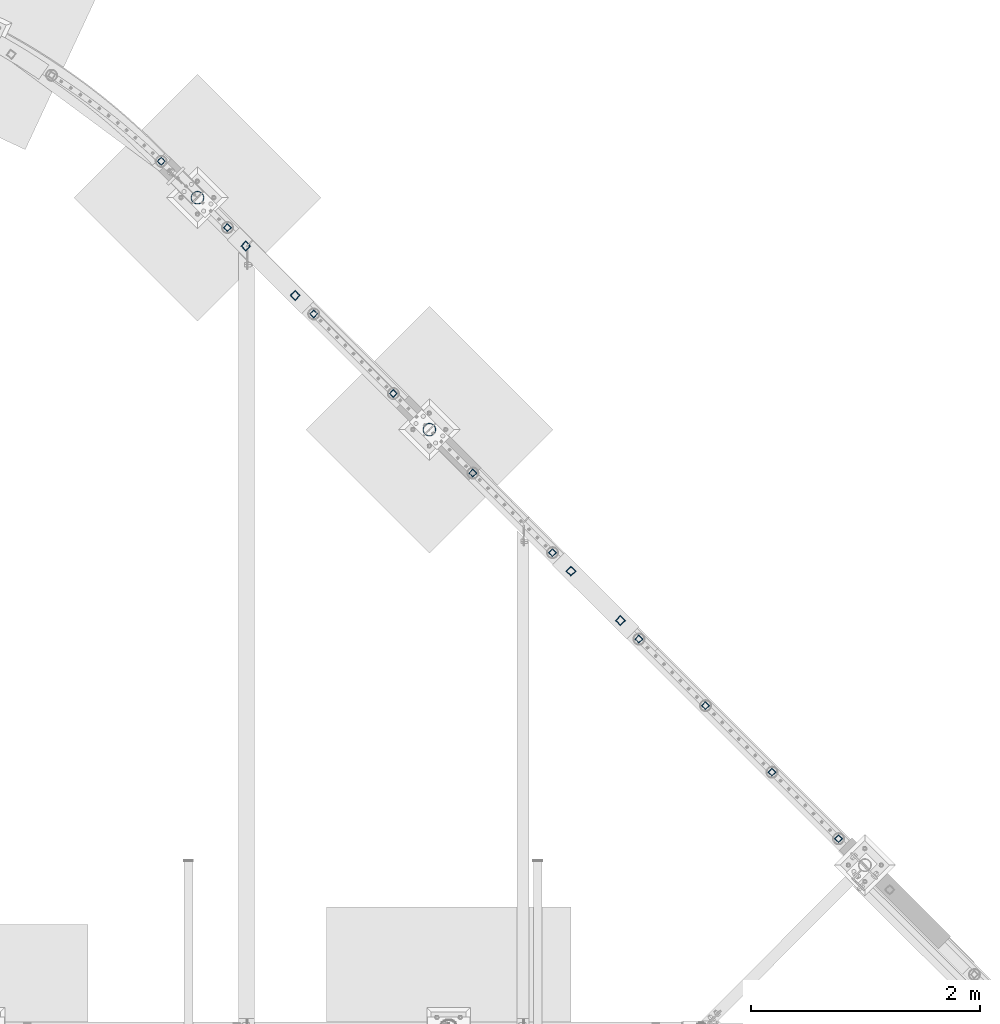
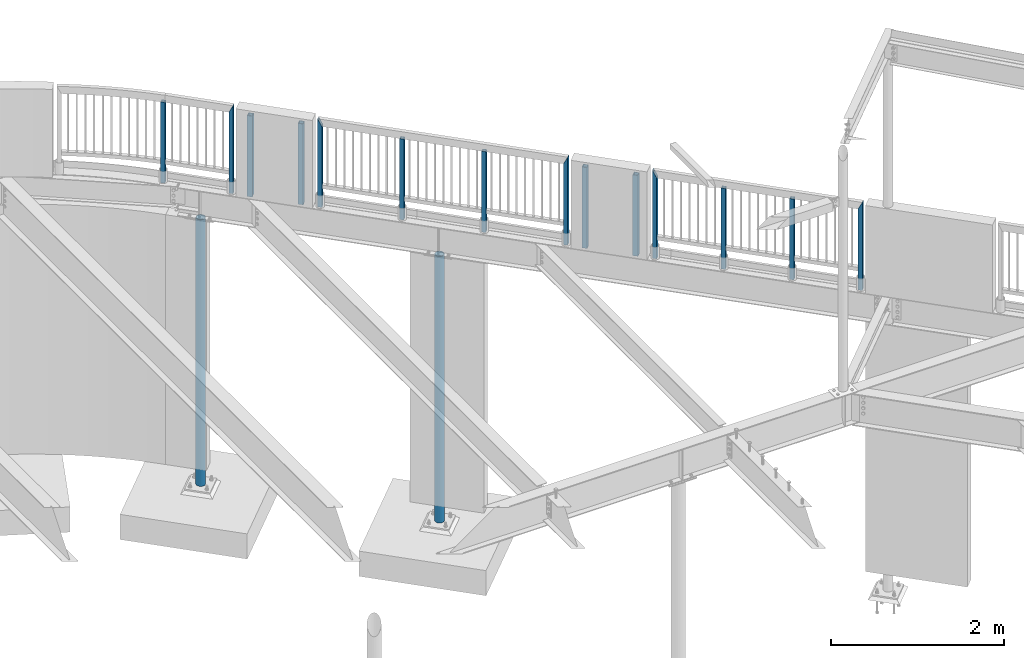
# One storey, part 131 of 975: 16 columns.
"""IFC2X3 building model written with IfcOpenShell, lengths in millimetres."""

from ifc_helpers import new_model, si_unit, frame, origin_with_axes, place, context, subcontext, project, spatial, faceted_brep, material, type_object, element, save


model = new_model("IFC2X3")

# Units and contexts
model_context = context("Model", 3, precision=1e-05, world=origin_with_axes())
body_context = subcontext(model_context, "Body", "Model", "MODEL_VIEW")
ifc_project = project(units=[si_unit("LENGTHUNIT", "METRE", prefix="MILLI"), si_unit("AREAUNIT", "SQUARE_METRE"), si_unit("VOLUMEUNIT", "CUBIC_METRE"), si_unit("MASSUNIT", "GRAM", prefix="KILO"), si_unit("TIMEUNIT", "SECOND"), si_unit("PLANEANGLEUNIT", "RADIAN"), si_unit("SOLIDANGLEUNIT", "STERADIAN"), si_unit("THERMODYNAMICTEMPERATUREUNIT", "DEGREE_CELSIUS"), si_unit("LUMINOUSINTENSITYUNIT", "LUMEN")], contexts=[model_context])

# Site, building, storey
site_placement = place(None, origin_with_axes())
site = spatial("IfcSite", under=ifc_project, at=site_placement, CompositionType="ELEMENT")
building_placement = place(site_placement, origin_with_axes())
building = spatial("IfcBuilding", under=site, at=building_placement, Name="Undefined", CompositionType="ELEMENT")
storey_placement = place(building_placement, origin_with_axes())
storey = spatial("IfcBuildingStorey", under=building, at=storey_placement, Name="Undefined", CompositionType="ELEMENT", Elevation=0.0)

# Columns
ifc_material_1 = material()
column_type_1 = type_object("IfcColumnType", Name="HSS2X2X.188_TUBES", PredefinedType="NOTDEFINED")
column_1_placement = place(storey_placement, frame((20414.5989551812, 28221.5825873175, 3937.00002018607), z_axis=(-0.707106781186601, 0.707106781186494, 2.36468622460961e-14), x_axis=(0.0, 0.0, 1.0)))
element("IfcColumn", 1, at=column_1_placement, inside=storey, type_object=column_type_1, material=ifc_material_1, Name="HANDRAIL", ObjectType="HSS2X2X.188_TUBES", context=body_context, shape_type="Brep", body=[
    faceted_brep([(0.0, 20.6374999999753, -20.6375000000298), (0.0, -20.6375000000153, -20.6375000000153), (1142.99998821453, -20.6374999999462, -20.6374999999534), (1142.99998821453, 20.6374999999462, -20.6374999999516), (0.0, -20.6374999999825, 20.6375000000335), (1142.9999881907, -20.6375000000262, 20.6375000000335), (0.0, 20.6375000000116, 20.6375000000189), (1142.99998829488, 20.6375000000335, 20.637500000048), (0.0, 25.3999999999724, -25.4000000000342), (0.0, 25.400000000016, 25.4000000000196), (1143.0, 25.4000000000051, 25.4000000000378), (1143.0, 25.4000000000433, -25.4000000000087), (0.0, -25.399999999976, 25.4000000000378), (1143.0, -25.4000000000451, 25.4000000000087), (0.0, -25.400000000016, -25.4000000000196), (1143.0, -25.4000000000106, -25.4000000000451)], [[[0, 1, 2, 3]], [[1, 4, 5, 2]], [[4, 6, 7, 5]], [[6, 0, 3, 7]], [[8, 9, 10, 11]], [[9, 12, 13, 10]], [[12, 14, 15, 13]], [[14, 8, 11, 15]], [[13, 15, 11, 10], [5, 7, 3, 2]], [[14, 12, 9, 8], [6, 4, 1, 0]]]),
])
column_2_placement = place(storey_placement, frame((20992.0520801812, 27642.3435253175, 3937.00002018607), z_axis=(-0.707106781186601, 0.707106781186494, 2.36468622460961e-14), x_axis=(0.0, 0.0, 1.0)))
element("IfcColumn", 2, at=column_2_placement, inside=storey, type_object=column_type_1, material=ifc_material_1, Name="HANDRAIL", ObjectType="HSS2X2X.188_TUBES", context=body_context, shape_type="Brep", body=[
    faceted_brep([(0.0, 20.6374999999753, -20.6375000000298), (0.0, -20.6375000000153, -20.6375000000153), (1235.074979717, -20.6374999999462, -20.6374999999462), (1234.95979254369, 20.6374999999534, -20.6374999999462), (0.0, -20.6374999999825, 20.6375000000335), (1152.64016697719, -20.6374999999462, 20.6374999999516), (0.0, 20.6375000000116, 20.6375000000189), (1152.52497980387, 20.6374999999534, 20.6374999999534), (0.0, 25.3999999999724, -25.4000000000342), (0.0, 25.400000000016, 25.4000000000196), (1143.0, 25.4000000000051, 25.4000000000378), (1244.45821087828, 25.3999999999432, -25.3999999999342), (0.0, -25.399999999976, 25.4000000000378), (1143.14174864259, -25.399999999936, 25.3999999999414), (0.0, -25.400000000016, -25.4000000000196), (1244.59997970698, -25.399999999936, -25.399999999936)], [[[0, 1, 2, 3]], [[1, 4, 5, 2]], [[4, 6, 7, 5]], [[6, 0, 3, 7]], [[8, 9, 10, 11]], [[9, 12, 13, 10]], [[12, 14, 15, 13]], [[14, 8, 11, 15]], [[13, 15, 11, 10], [5, 7, 3, 2]], [[14, 12, 9, 8], [6, 4, 1, 0]]]),
])
for number, where, z_axis, x_axis, name in (
    (3, (25744.4987497212, 22890.0361789292, 3937.0), (-0.707106781186601, 0.707106781186494, 2.36468622460961e-14), (-5.04999999806568e-07, 5.04999999806568e-07, 0.999999999999745), "HANDRAIL"),
    (4, (23134.193376057, 25500.2478312396, 3937.00001429355), (-0.707106781186601, 0.707106781186494, 2.36468622460961e-14), (-5.04999999806568e-07, 5.04999999806568e-07, 0.999999999999745), "HANDRAIL"),
):
    element("IfcColumn", number, at=place(storey_placement, frame(where, z_axis=z_axis, x_axis=x_axis)), inside=storey, type_object=column_type_1, material=ifc_material_1, Name=name, ObjectType="HSS2X2X.188_TUBES", context=body_context, shape_type="Brep", body=[
        faceted_brep([(0.0, 20.6374999999753, -20.6375000000298), (0.0, -20.6375000000153, -20.6375000000153), (1142.99998821453, -20.6374999999462, -20.6374999999534), (1142.99998821453, 20.6374999999462, -20.6374999999516), (0.0, -20.6374999999825, 20.6375000000335), (1142.9999881907, -20.6375000000262, 20.6375000000335), (0.0, 20.6375000000116, 20.6375000000189), (1142.99998829488, 20.6375000000335, 20.637500000048), (0.0, 25.3999999999724, -25.4000000000342), (0.0, 25.400000000016, 25.4000000000196), (1143.0, 25.4000000000051, 25.4000000000378), (1143.0, 25.4000000000433, -25.4000000000087), (0.0, -25.399999999976, 25.4000000000378), (1143.0, -25.4000000000451, 25.4000000000087), (0.0, -25.400000000016, -25.4000000000196), (1143.0, -25.4000000000106, -25.4000000000451)], [[[0, 1, 2, 3]], [[1, 4, 5, 2]], [[4, 6, 7, 5]], [[6, 0, 3, 7]], [[8, 9, 10, 11]], [[9, 12, 13, 10]], [[12, 14, 15, 13]], [[14, 8, 11, 15]], [[13, 15, 11, 10], [5, 7, 3, 2]], [[14, 12, 9, 8], [6, 4, 1, 0]]]),
    ])
column_3_placement = place(storey_placement, frame((21745.3208301812, 26889.2732113175, 3937.00002018607), z_axis=(-0.707106781186601, 0.707106781186494, 2.36468622460961e-14), x_axis=(0.0, 0.0, 1.0)))
element("IfcColumn", 5, at=column_3_placement, inside=storey, type_object=column_type_1, material=ifc_material_1, Name="HANDRAIL", ObjectType="HSS2X2X.188_TUBES", context=body_context, shape_type="Brep", body=[
    faceted_brep([(0.0, 20.6374999999753, -20.6375000000298), (0.0, -20.6375000000153, -20.6375000000153), (1152.52497983932, -20.6374999999462, -20.6374999999525), (1152.5298588527, 20.6374999999998, -20.6375000005173), (0.0, -20.6374999999825, 20.6375000000335), (1235.07010081906, -20.6374999999998, 20.6374999994514), (0.0, 20.6375000000116, 20.6375000000189), (1235.07497982248, 20.6374999999534, 20.6374999999471), (0.0, 25.3999999999724, -25.4000000000342), (0.0, 25.400000000016, 25.4000000000196), (1244.59997982054, 25.399999999936, 25.3999999999351), (1143.00598477966, 25.4000000000001, -25.4000000005108), (0.0, -25.399999999976, 25.4000000000378), (1244.59397489211, -25.4000000000001, 25.3999999994448), (0.0, -25.400000000016, -25.4000000000196), (1143.0, -25.4000000000106, -25.4000000000451)], [[[0, 1, 2, 3]], [[1, 4, 5, 2]], [[4, 6, 7, 5]], [[6, 0, 3, 7]], [[8, 9, 10, 11]], [[9, 12, 13, 10]], [[12, 14, 15, 13]], [[14, 8, 11, 15]], [[13, 15, 11, 10], [5, 7, 3, 2]], [[14, 12, 9, 8], [6, 4, 1, 0]]]),
])
column_4_placement = place(storey_placement, frame((22439.8001211003, 26194.8029317337, 3937.00001429355), z_axis=(-0.707106781186601, 0.707106781186494, 2.36468622460961e-14), x_axis=(-5.04999999806568e-07, 5.04999999806568e-07, 0.999999999999745)))
element("IfcColumn", 6, at=column_4_placement, inside=storey, type_object=column_type_1, material=ifc_material_1, Name="HANDRAIL", ObjectType="HSS2X2X.188_TUBES", context=body_context, shape_type="Brep", body=[
    faceted_brep([(0.0, 20.6374999999753, -20.6375000000298), (0.0, -20.6375000000153, -20.6375000000153), (1142.99998821453, -20.6374999999462, -20.6374999999534), (1142.99998821453, 20.6374999999462, -20.6374999999516), (0.0, -20.6374999999825, 20.6375000000335), (1142.9999881907, -20.6375000000262, 20.6375000000335), (0.0, 20.6375000000116, 20.6375000000189), (1142.99998829488, 20.6375000000335, 20.637500000048), (0.0, 25.3999999999724, -25.4000000000342), (0.0, 25.400000000016, 25.4000000000196), (1143.0, 25.4000000000051, 25.4000000000378), (1143.0, 25.4000000000433, -25.4000000000087), (0.0, -25.399999999976, 25.4000000000378), (1143.0, -25.4000000000451, 25.4000000000087), (0.0, -25.400000000016, -25.4000000000196), (1143.0, -25.4000000000106, -25.4000000000451)], [[[0, 1, 2, 3]], [[1, 4, 5, 2]], [[4, 6, 7, 5]], [[6, 0, 3, 7]], [[8, 9, 10, 11]], [[9, 12, 13, 10]], [[12, 14, 15, 13]], [[14, 8, 11, 15]], [[13, 15, 11, 10], [5, 7, 3, 2]], [[14, 12, 9, 8], [6, 4, 1, 0]]]),
])
column_5_placement = place(storey_placement, frame((23828.6202251717, 24805.7275258393, 3937.00001178547), z_axis=(-0.707106781186601, 0.707106781186494, 2.36468622460961e-14), x_axis=(0.0, 0.0, 1.0)))
element("IfcColumn", 7, at=column_5_placement, inside=storey, type_object=column_type_1, material=ifc_material_1, Name="HANDRAIL", ObjectType="HSS2X2X.188_TUBES", context=body_context, shape_type="Brep", body=[
    faceted_brep([(0.0, 20.6374999999753, -20.6375000000298), (0.0, -20.6375000000153, -20.6375000000153), (1235.074979717, -20.6374999999462, -20.6374999999462), (1235.07010917575, 20.6374999999871, -20.6375000000007), (0.0, -20.6374999999825, 20.6375000000335), (1152.5298672094, -20.6375000000121, 20.6375000000007), (0.0, 20.6375000000116, 20.6375000000189), (1152.52497980387, 20.6374999999534, 20.6374999999534), (0.0, 25.3999999999724, -25.4000000000342), (0.0, 25.400000000016, 25.4000000000196), (1143.0, 25.4000000000051, 25.4000000000378), (1244.5939832488, 25.3999999999869, -25.4000000000015), (0.0, -25.399999999976, 25.4000000000378), (1143.00599313636, -25.4000000000124, 25.4000000000015), (0.0, -25.400000000016, -25.4000000000196), (1244.59997970698, -25.399999999936, -25.399999999936)], [[[0, 1, 2, 3]], [[1, 4, 5, 2]], [[4, 6, 7, 5]], [[6, 0, 3, 7]], [[8, 9, 10, 11]], [[9, 12, 13, 10]], [[12, 14, 15, 13]], [[14, 8, 11, 15]], [[13, 15, 11, 10], [5, 7, 3, 2]], [[14, 12, 9, 8], [6, 4, 1, 0]]]),
])
column_6_placement = place(storey_placement, frame((24583.0999040427, 24051.5357113111, 3937.00002018607), z_axis=(-0.707106781186601, 0.707106781186494, 2.36468622460961e-14), x_axis=(0.0, 0.0, 1.0)))
element("IfcColumn", 8, at=column_6_placement, inside=storey, type_object=column_type_1, material=ifc_material_1, Name="HANDRAIL", ObjectType="HSS2X2X.188_TUBES", context=body_context, shape_type="Brep", body=[
    faceted_brep([(0.0, 20.6374999999753, -20.6375000000298), (0.0, -20.6375000000153, -20.6375000000153), (1152.52497983932, -20.6374999999462, -20.6374999999525), (1152.52900291014, 20.6374999999462, -20.6374999999489), (0.0, -20.6374999999825, 20.6375000000335), (1235.07095675167, -20.6374999999462, 20.6374999999471), (0.0, 20.6375000000116, 20.6375000000189), (1235.07497982248, 20.6374999999534, 20.6374999999471), (0.0, 25.3999999999724, -25.4000000000342), (0.0, 25.400000000016, 25.4000000000196), (1244.59997982054, 25.399999999936, 25.3999999999351), (1143.00493131304, 25.399999999936, -25.3999999999387), (0.0, -25.399999999976, 25.4000000000378), (1244.59502834876, -25.399999999936, 25.3999999999369), (0.0, -25.400000000016, -25.4000000000196), (1143.0, -25.4000000000106, -25.4000000000451)], [[[0, 1, 2, 3]], [[1, 4, 5, 2]], [[4, 6, 7, 5]], [[6, 0, 3, 7]], [[8, 9, 10, 11]], [[9, 12, 13, 10]], [[12, 14, 15, 13]], [[14, 8, 11, 15]], [[13, 15, 11, 10], [5, 7, 3, 2]], [[14, 12, 9, 8], [6, 4, 1, 0]]]),
])
column_7_placement = place(storey_placement, frame((25163.8423448718, 23470.8283555666, 3937.00001429334), z_axis=(-0.707106781186601, 0.707106781186494, 2.36468622460961e-14), x_axis=(-5.04999999806568e-07, 5.04999999806568e-07, 0.999999999999745)))
element("IfcColumn", 9, at=column_7_placement, inside=storey, type_object=column_type_1, material=ifc_material_1, Name="HANDRAIL", ObjectType="HSS2X2X.188_TUBES", context=body_context, shape_type="Brep", body=[
    faceted_brep([(0.0, 20.6374999999753, -20.6375000000298), (0.0, -20.6375000000153, -20.6375000000153), (1142.99998821453, -20.6374999999462, -20.6374999999534), (1142.99998821453, 20.6374999999462, -20.6374999999516), (0.0, -20.6374999999825, 20.6375000000335), (1142.9999881907, -20.6375000000262, 20.6375000000335), (0.0, 20.6375000000116, 20.6375000000189), (1142.99998829488, 20.6375000000335, 20.637500000048), (0.0, 25.3999999999724, -25.4000000000342), (0.0, 25.400000000016, 25.4000000000196), (1143.0, 25.4000000000051, 25.4000000000378), (1143.0, 25.4000000000433, -25.4000000000087), (0.0, -25.399999999976, 25.4000000000378), (1143.0, -25.4000000000451, 25.4000000000087), (0.0, -25.400000000016, -25.4000000000196), (1143.0, -25.4000000000106, -25.4000000000451)], [[[0, 1, 2, 3]], [[1, 4, 5, 2]], [[4, 6, 7, 5]], [[6, 0, 3, 7]], [[8, 9, 10, 11]], [[9, 12, 13, 10]], [[12, 14, 15, 13]], [[14, 8, 11, 15]], [[13, 15, 11, 10], [5, 7, 3, 2]], [[14, 12, 9, 8], [6, 4, 1, 0]]]),
])
column_8_placement = place(storey_placement, frame((26325.1887487134, 22309.2787974008, 3937.00001178547), z_axis=(-0.707106781186601, 0.707106781186494, 2.36468622460961e-14), x_axis=(0.0, 0.0, 1.0)))
element("IfcColumn", 10, at=column_8_placement, inside=storey, type_object=column_type_1, material=ifc_material_1, Name="HANDRAIL", ObjectType="HSS2X2X.188_TUBES", context=body_context, shape_type="Brep", body=[
    faceted_brep([(0.0, 20.6374999999753, -20.6375000000298), (0.0, -20.6375000000153, -20.6375000000153), (1235.074979717, -20.6374999999462, -20.6374999999462), (1235.07091767483, 20.6374999999871, -20.6375000000007), (0.0, -20.6374999999825, 20.6375000000335), (1152.52905859553, -20.6375000000121, 20.6375000000007), (0.0, 20.6375000000116, 20.6375000000189), (1152.52497980387, 20.6374999999534, 20.6374999999534), (0.0, 25.3999999999724, -25.4000000000342), (0.0, 25.400000000016, 25.4000000000196), (1143.0, 25.4000000000051, 25.4000000000378), (1244.59503672188, 25.399999999936, -25.3999999999396), (0.0, -25.399999999976, 25.4000000000378), (1143.00493968616, -25.399999999936, 25.399999999936), (0.0, -25.400000000016, -25.4000000000196), (1244.59997970698, -25.399999999936, -25.399999999936)], [[[0, 1, 2, 3]], [[1, 4, 5, 2]], [[4, 6, 7, 5]], [[6, 0, 3, 7]], [[8, 9, 10, 11]], [[9, 12, 13, 10]], [[12, 14, 15, 13]], [[14, 8, 11, 15]], [[13, 15, 11, 10], [5, 7, 3, 2]], [[14, 12, 9, 8], [6, 4, 1, 0]]]),
])
column_type_2 = type_object("IfcColumnType", Name="HSS2-1/2X2-1/2X1/4", PredefinedType="NOTDEFINED")
for number, where, z_axis, x_axis in (
    (11, (24421.4420888213, 24213.1973175499, 3937.0), (0.707115470133164, 0.70709809213316, 0.0), (0.0, 0.0, 1.0)),
    (12, (23990.395091857, 24644.2549081431, 3937.0), (0.707115470133164, 0.70709809213316, 0.0), (0.0, 0.0, 1.0)),
    (13, (21583.7233873893, 27050.9266126107, 3937.0), (0.707115470133164, 0.70709809213316, 0.0), (0.0, 0.0, 1.0)),
    (14, (21152.6313806827, 27482.0186193173, 3937.0), (0.707115470133164, 0.70709809213316, 0.0), (0.0, 0.0, 1.0)),
):
    element("IfcColumn", number, at=place(storey_placement, frame(where, z_axis=z_axis, x_axis=x_axis)), inside=storey, type_object=column_type_2, material=ifc_material_1, ObjectType="HSS2-1/2X2-1/2X1/4", context=body_context, shape_type="Brep", body=[
        faceted_brep([(0.0, 25.3999999999724, -25.4000000000342), (0.0, -25.400000000016, -25.4000000000196), (1143.0, -25.4000000000106, -25.4000000000451), (1143.0, 25.4000000000433, -25.4000000000087), (0.0, -25.399999999976, 25.4000000000378), (1143.0, -25.4000000000451, 25.4000000000087), (0.0, 25.400000000016, 25.4000000000196), (1143.0, 25.4000000000051, 25.4000000000378), (-5.45696821063757e-11, 31.7499999999909, -31.75000000002), (0.0, 31.7500000000127, 31.7500000000582), (1143.0, 31.7500000000127, 31.7500000000582), (1143.0, 31.7500000000546, -31.7500000000146), (0.0, -31.7500000000564, 31.7500000000073), (1143.0, -31.7500000000564, 31.7500000000073), (0.0, -31.7500000000146, -31.7500000000582), (1143.0, -31.7500000000146, -31.7500000000582)], [[[0, 1, 2, 3]], [[1, 4, 5, 2]], [[4, 6, 7, 5]], [[6, 0, 3, 7]], [[8, 9, 10, 11]], [[9, 12, 13, 10]], [[12, 14, 15, 13]], [[14, 8, 11, 15]], [[13, 15, 11, 10], [5, 7, 3, 2]], [[14, 12, 9, 8], [6, 4, 1, 0]]]),
    ])
ifc_material_2 = material(Name="STEEL/A53")
column_type_3 = type_object("IfcColumnType", Name="PIPE4STD", PredefinedType="NOTDEFINED")
column_9_placement = place(storey_placement, frame((20731.1625, 27903.4875, -266.7), z_axis=(-0.707106781186601, 0.707106781186494, 2.36468622460961e-14), x_axis=(0.0, 0.0, 1.0)))
element("IfcColumn", 15, at=column_9_placement, inside=storey, type_object=column_type_3, material=ifc_material_2, Name="COLUMN", ObjectType="PIPE4STD", context=body_context, shape_type="Brep", body=[
    faceted_brep([(19.0500000000025, -51.1301999999996, 0.0), (19.0500000000025, -48.6277098894743, 15.8001007257917), (3787.775, -48.6277098893624, 15.8001007257553), (3787.775, -51.1301999998759, 3.63797880709171e-12), (19.0500000000025, -41.3652007257897, 30.0535775067656), (3787.775, -41.3652007256969, 30.0535775066928), (19.0500000000025, -30.0535775067647, 41.3652007257915), (3787.775, -30.0535775066892, 41.3652007256933), (19.0500000000025, -15.8001007257899, 48.6277098894752), (3787.775, -15.8001007257553, 48.6277098893624), (19.0500000000025, 0.0, 51.1301999999996), (3787.775, -7.27595761418343e-12, 51.1301999998796), (19.0500000000025, 15.8001007257899, 48.6277098894752), (3787.775, 15.8001007257481, 48.6277098893606), (19.0500000000025, 30.0535775067647, 41.3652007257915), (3787.775, 30.0535775066892, 41.3652007256915), (19.0500000000025, 41.3652007257897, 30.0535775067656), (3787.775, 41.3652007256824, 30.0535775066928), (19.0500000000025, 48.6277098894743, 15.8001007257917), (3787.775, 48.6277098893552, 15.8001007257553), (19.0500000000025, 51.1301999999996, 0.0), (3787.775, 51.1301999998759, 1.81898940354586e-12), (19.0500000000025, 48.6277098894743, -15.8001007257917), (3787.775, 48.6277098893552, -15.8001007257481), (19.0500000000025, 41.3652007257897, -30.0535775067656), (3787.775, 41.3652007256896, -30.0535775066874), (19.0500000000025, 30.0535775067647, -41.3652007257915), (3787.775, 30.0535775066892, -41.3652007256878), (19.0500000000025, 15.8001007257899, -48.6277098894752), (3787.775, 15.8001007257481, -48.6277098893552), (19.0500000000025, 0.0, -51.1301999999996), (3787.775, 0.0, -51.1301999998741), (19.0500000000025, -15.8001007257899, -48.6277098894752), (3787.775, -15.8001007257553, -48.6277098893552), (19.0500000000025, -30.0535775067647, -41.3652007257915), (3787.775, -30.0535775066892, -41.365200725686), (19.0500000000025, -41.3652007257897, -30.0535775067656), (3787.775, -41.3652007256896, -30.0535775066874), (19.0500000000025, -48.6277098894743, -15.8001007257917), (3787.775, -48.6277098893624, -15.8001007257499), (19.0500000000025, -57.1499999999996, 0.0), (19.0500000000025, -54.3528799062678, -17.6603212285299), (3787.775, -54.3528799061387, -17.6603212284826), (3787.775, -57.1499999998705, 3.63797880709171e-12), (19.0500000000025, -46.2353212285279, -33.5919271685161), (3787.775, -46.2353212284215, -33.5919271684324), (19.0500000000025, -33.5919271685152, -46.235321228527), (3787.775, -33.5919271684397, -46.2353212284161), (19.0500000000025, -17.6603212285281, -54.3528799062697), (3787.775, -17.6603212284899, -54.3528799061332), (19.0500000000025, 0.0, -57.1500000000015), (3787.775, 0.0, -57.1499999998614), (19.0500000000025, 17.6603212285281, -54.3528799062697), (3787.775, 17.6603212284826, -54.3528799061314), (19.0500000000025, 33.5919271685152, -46.235321228527), (3787.775, 33.5919271684324, -46.2353212284143), (19.0500000000025, 46.2353212285279, -33.5919271685161), (3787.775, 46.2353212284143, -33.5919271684324), (19.0500000000025, 54.3528799062678, -17.6603212285299), (3787.775, 54.3528799061314, -17.6603212284826), (19.0500000000025, 57.1499999999996, 0.0), (3787.775, 57.1499999998632, 1.81898940354586e-12), (19.0500000000025, 54.3528799062678, 17.6603212285299), (3787.775, 54.3528799061314, 17.6603212284881), (19.0500000000025, 46.2353212285279, 33.5919271685161), (3787.775, 46.2353212284143, 33.5919271684379), (19.0500000000025, 33.5919271685152, 46.235321228527), (3787.775, 33.5919271684324, 46.2353212284215), (19.0500000000025, 17.6603212285281, 54.3528799062697), (3787.775, 17.6603212284826, 54.3528799061387), (19.0500000000025, 0.0, 57.1500000000015), (3787.775, -7.27595761418343e-12, 57.1499999998668), (19.0500000000025, -17.6603212285281, 54.3528799062697), (3787.775, -17.6603212284899, 54.3528799061369), (19.0500000000025, -33.5919271685152, 46.235321228527), (3787.775, -33.5919271684397, 46.2353212284197), (19.0500000000025, -46.2353212285279, 33.5919271685161), (3787.775, -46.2353212284215, 33.5919271684379), (19.0500000000025, -54.3528799062678, 17.6603212285299), (3787.775, -54.3528799061387, 17.6603212284881)], [[[0, 1, 2, 3]], [[1, 4, 5, 2]], [[4, 6, 7, 5]], [[6, 8, 9, 7]], [[8, 10, 11, 9]], [[10, 12, 13, 11]], [[12, 14, 15, 13]], [[14, 16, 17, 15]], [[16, 18, 19, 17]], [[18, 20, 21, 19]], [[20, 22, 23, 21]], [[22, 24, 25, 23]], [[24, 26, 27, 25]], [[26, 28, 29, 27]], [[28, 30, 31, 29]], [[30, 32, 33, 31]], [[32, 34, 35, 33]], [[34, 36, 37, 35]], [[36, 38, 39, 37]], [[38, 0, 3, 39]], [[40, 41, 42, 43]], [[41, 44, 45, 42]], [[44, 46, 47, 45]], [[46, 48, 49, 47]], [[48, 50, 51, 49]], [[50, 52, 53, 51]], [[52, 54, 55, 53]], [[54, 56, 57, 55]], [[56, 58, 59, 57]], [[58, 60, 61, 59]], [[60, 62, 63, 61]], [[62, 64, 65, 63]], [[64, 66, 67, 65]], [[66, 68, 69, 67]], [[68, 70, 71, 69]], [[70, 72, 73, 71]], [[72, 74, 75, 73]], [[74, 76, 77, 75]], [[76, 78, 79, 77]], [[78, 40, 43, 79]], [[45, 47, 49, 51, 53, 55, 57, 59, 61, 63, 65, 67, 69, 71, 73, 75, 77, 79, 43, 42], [5, 7, 9, 11, 13, 15, 17, 19, 21, 23, 25, 27, 29, 31, 33, 35, 37, 39, 3, 2]], [[78, 76, 74, 72, 70, 68, 66, 64, 62, 60, 58, 56, 54, 52, 50, 48, 46, 44, 41, 40], [38, 36, 34, 32, 30, 28, 26, 24, 22, 20, 18, 16, 14, 12, 10, 8, 6, 4, 1, 0]]]),
])
column_10_placement = place(storey_placement, frame((22755.225, 25879.425, -266.7), z_axis=(-0.707106781186601, 0.707106781186494, 2.36468622460961e-14), x_axis=(0.0, 0.0, 1.0)))
element("IfcColumn", 16, at=column_10_placement, inside=storey, type_object=column_type_3, material=ifc_material_2, Name="COLUMN", ObjectType="PIPE4STD", context=body_context, shape_type="Brep", body=[
    faceted_brep([(19.0500000000025, -51.1301999999996, 0.0), (19.0500000000025, -48.6277098894743, 15.8001007257917), (3787.775, -48.6277098893624, 15.8001007257553), (3787.775, -51.1301999998759, 3.63797880709171e-12), (19.0500000000025, -41.3652007257897, 30.0535775067656), (3787.775, -41.3652007256969, 30.0535775066928), (19.0500000000025, -30.0535775067647, 41.3652007257915), (3787.775, -30.0535775066892, 41.3652007256933), (19.0500000000025, -15.8001007257899, 48.6277098894752), (3787.775, -15.8001007257553, 48.6277098893624), (19.0500000000025, 0.0, 51.1301999999996), (3787.775, -7.27595761418343e-12, 51.1301999998796), (19.0500000000025, 15.8001007257899, 48.6277098894752), (3787.775, 15.8001007257481, 48.6277098893606), (19.0500000000025, 30.0535775067647, 41.3652007257915), (3787.775, 30.0535775066892, 41.3652007256915), (19.0500000000025, 41.3652007257897, 30.0535775067656), (3787.775, 41.3652007256824, 30.0535775066928), (19.0500000000025, 48.6277098894743, 15.8001007257917), (3787.775, 48.6277098893552, 15.8001007257553), (19.0500000000025, 51.1301999999996, 0.0), (3787.775, 51.1301999998759, 1.81898940354586e-12), (19.0500000000025, 48.6277098894743, -15.8001007257917), (3787.775, 48.6277098893552, -15.8001007257481), (19.0500000000025, 41.3652007257897, -30.0535775067656), (3787.775, 41.3652007256896, -30.0535775066874), (19.0500000000025, 30.0535775067647, -41.3652007257915), (3787.775, 30.0535775066892, -41.3652007256878), (19.0500000000025, 15.8001007257899, -48.6277098894752), (3787.775, 15.8001007257481, -48.6277098893552), (19.0500000000025, 0.0, -51.1301999999996), (3787.775, 0.0, -51.1301999998741), (19.0500000000025, -15.8001007257899, -48.6277098894752), (3787.775, -15.8001007257553, -48.6277098893552), (19.0500000000025, -30.0535775067647, -41.3652007257915), (3787.775, -30.0535775066892, -41.365200725686), (19.0500000000025, -41.3652007257897, -30.0535775067656), (3787.775, -41.3652007256896, -30.0535775066874), (19.0500000000025, -48.6277098894743, -15.8001007257917), (3787.775, -48.6277098893624, -15.8001007257499), (19.0500000000025, -57.1499999999996, 0.0), (19.0500000000025, -54.3528799062678, -17.6603212285299), (3787.775, -54.3528799061387, -17.6603212284826), (3787.775, -57.1499999998705, 3.63797880709171e-12), (19.0500000000025, -46.2353212285279, -33.5919271685161), (3787.775, -46.2353212284215, -33.5919271684324), (19.0500000000025, -33.5919271685152, -46.235321228527), (3787.775, -33.5919271684397, -46.2353212284161), (19.0500000000025, -17.6603212285281, -54.3528799062697), (3787.775, -17.6603212284899, -54.3528799061332), (19.0500000000025, 0.0, -57.1500000000015), (3787.775, 0.0, -57.1499999998614), (19.0500000000025, 17.6603212285281, -54.3528799062697), (3787.775, 17.6603212284826, -54.3528799061314), (19.0500000000025, 33.5919271685152, -46.235321228527), (3787.775, 33.5919271684324, -46.2353212284143), (19.0500000000025, 46.2353212285279, -33.5919271685161), (3787.775, 46.2353212284143, -33.5919271684324), (19.0500000000025, 54.3528799062678, -17.6603212285299), (3787.775, 54.3528799061314, -17.6603212284826), (19.0500000000025, 57.1499999999996, 0.0), (3787.775, 57.1499999998632, 1.81898940354586e-12), (19.0500000000025, 54.3528799062678, 17.6603212285299), (3787.775, 54.3528799061314, 17.6603212284881), (19.0500000000025, 46.2353212285279, 33.5919271685161), (3787.775, 46.2353212284143, 33.5919271684379), (19.0500000000025, 33.5919271685152, 46.235321228527), (3787.775, 33.5919271684324, 46.2353212284215), (19.0500000000025, 17.6603212285281, 54.3528799062697), (3787.775, 17.6603212284826, 54.3528799061387), (19.0500000000025, 0.0, 57.1500000000015), (3787.775, -7.27595761418343e-12, 57.1499999998668), (19.0500000000025, -17.6603212285281, 54.3528799062697), (3787.775, -17.6603212284899, 54.3528799061369), (19.0500000000025, -33.5919271685152, 46.235321228527), (3787.775, -33.5919271684397, 46.2353212284197), (19.0500000000025, -46.2353212285279, 33.5919271685161), (3787.775, -46.2353212284215, 33.5919271684379), (19.0500000000025, -54.3528799062678, 17.6603212285299), (3787.775, -54.3528799061387, 17.6603212284881)], [[[0, 1, 2, 3]], [[1, 4, 5, 2]], [[4, 6, 7, 5]], [[6, 8, 9, 7]], [[8, 10, 11, 9]], [[10, 12, 13, 11]], [[12, 14, 15, 13]], [[14, 16, 17, 15]], [[16, 18, 19, 17]], [[18, 20, 21, 19]], [[20, 22, 23, 21]], [[22, 24, 25, 23]], [[24, 26, 27, 25]], [[26, 28, 29, 27]], [[28, 30, 31, 29]], [[30, 32, 33, 31]], [[32, 34, 35, 33]], [[34, 36, 37, 35]], [[36, 38, 39, 37]], [[38, 0, 3, 39]], [[40, 41, 42, 43]], [[41, 44, 45, 42]], [[44, 46, 47, 45]], [[46, 48, 49, 47]], [[48, 50, 51, 49]], [[50, 52, 53, 51]], [[52, 54, 55, 53]], [[54, 56, 57, 55]], [[56, 58, 59, 57]], [[58, 60, 61, 59]], [[60, 62, 63, 61]], [[62, 64, 65, 63]], [[64, 66, 67, 65]], [[66, 68, 69, 67]], [[68, 70, 71, 69]], [[70, 72, 73, 71]], [[72, 74, 75, 73]], [[74, 76, 77, 75]], [[76, 78, 79, 77]], [[78, 40, 43, 79]], [[45, 47, 49, 51, 53, 55, 57, 59, 61, 63, 65, 67, 69, 71, 73, 75, 77, 79, 43, 42], [5, 7, 9, 11, 13, 15, 17, 19, 21, 23, 25, 27, 29, 31, 33, 35, 37, 39, 3, 2]], [[78, 76, 74, 72, 70, 68, 66, 64, 62, 60, 58, 56, 54, 52, 50, 48, 46, 44, 41, 40], [38, 36, 34, 32, 30, 28, 26, 24, 22, 20, 18, 16, 14, 12, 10, 8, 6, 4, 1, 0]]]),
])

save(model, "model.ifc")
